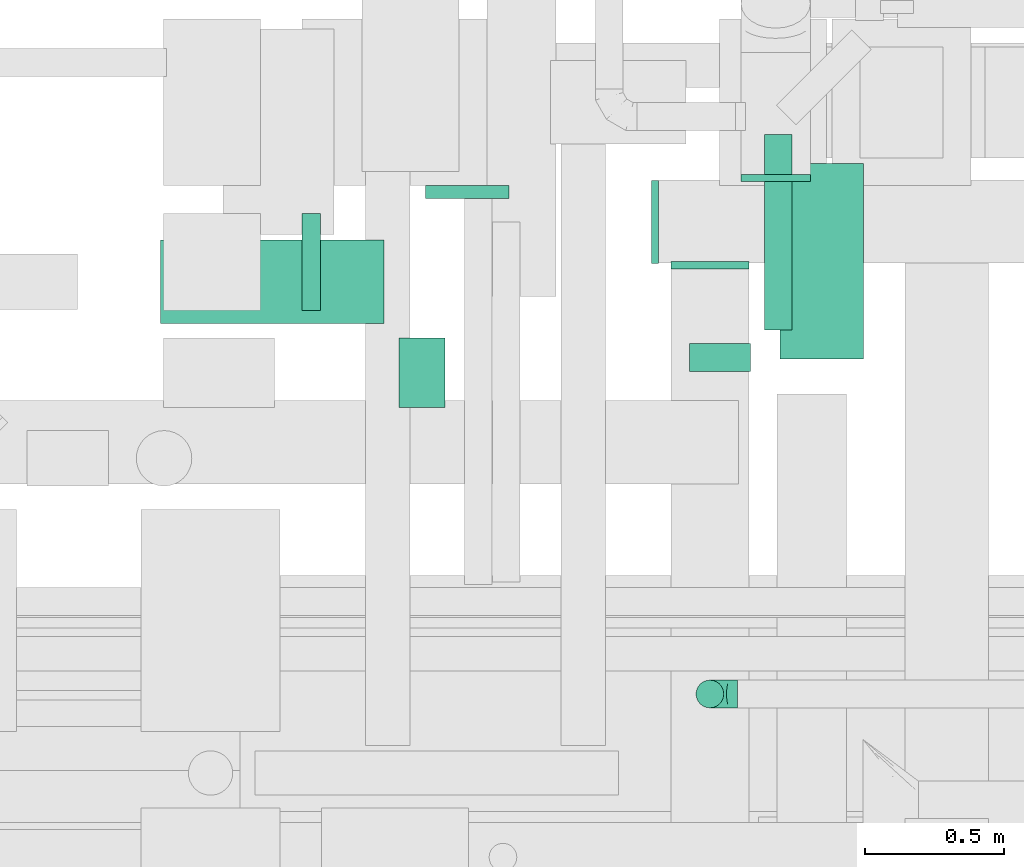
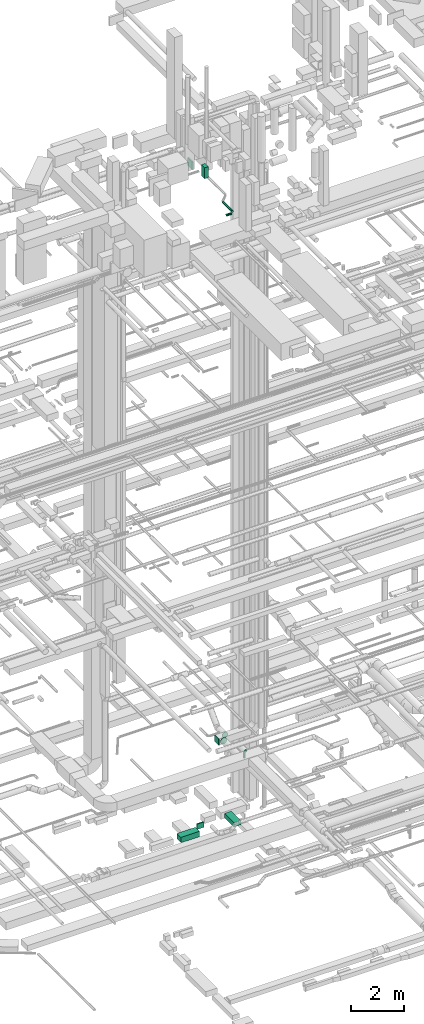
# One storey, part 132 of 337: 8 flow segments, 4 flow fittings.
"""IFC2X3 building model written with IfcOpenShell, lengths in millimetres."""

from ifc_helpers import new_model, entity, si_unit, converted_unit, derived_unit, direction, frame, origin, origin_2d_with_axis, place, context, subcontext, project, spatial, rectangle, circle, extrude, faceted_brep, source, transform, mapped, material, type_object, type_shapes, element, save


model = new_model("IFC2X3")

# Units and contexts
model_context = context("Model", 3, precision=0.01, world=origin(), true_north=direction((6.12303176911189e-17, 1.0)))
body_context = subcontext(model_context, "Body", "Model", "MODEL_VIEW")
ifc_project = project(units=[si_unit("LENGTHUNIT", "METRE", prefix="MILLI"), si_unit("AREAUNIT", "SQUARE_METRE"), si_unit("VOLUMEUNIT", "CUBIC_METRE"), converted_unit("PLANEANGLEUNIT", "DEGREE", entity("IfcRatioMeasure", 0.0174532925199433), si_unit("PLANEANGLEUNIT", "RADIAN"), dimensions=[0, 0, 0, 0, 0, 0, 0]), si_unit("MASSUNIT", "GRAM", prefix="KILO"), derived_unit("MASSDENSITYUNIT", [(si_unit("MASSUNIT", "GRAM", prefix="KILO"), 1), (si_unit("LENGTHUNIT", "METRE"), -3)]), derived_unit("MOMENTOFINERTIAUNIT", [(si_unit("LENGTHUNIT", "METRE"), 4)]), si_unit("TIMEUNIT", "SECOND"), si_unit("FREQUENCYUNIT", "HERTZ"), si_unit("THERMODYNAMICTEMPERATUREUNIT", "DEGREE_CELSIUS"), derived_unit("THERMALTRANSMITTANCEUNIT", [(si_unit("MASSUNIT", "GRAM", prefix="KILO"), 1), (si_unit("THERMODYNAMICTEMPERATUREUNIT", "KELVIN"), -1), (si_unit("TIMEUNIT", "SECOND"), -3)]), derived_unit("VOLUMETRICFLOWRATEUNIT", [(si_unit("LENGTHUNIT", "METRE"), 3), (si_unit("TIMEUNIT", "SECOND"), -1)]), derived_unit("MASSFLOWRATEUNIT", [(si_unit("MASSUNIT", "GRAM", prefix="KILO"), 1), (si_unit("TIMEUNIT", "SECOND"), -1)]), derived_unit("ROTATIONALFREQUENCYUNIT", [(si_unit("TIMEUNIT", "SECOND"), -1)]), si_unit("ELECTRICCURRENTUNIT", "AMPERE"), si_unit("ELECTRICVOLTAGEUNIT", "VOLT"), si_unit("POWERUNIT", "WATT"), si_unit("FORCEUNIT", "NEWTON", prefix="KILO"), si_unit("ILLUMINANCEUNIT", "LUX"), si_unit("LUMINOUSFLUXUNIT", "LUMEN"), si_unit("LUMINOUSINTENSITYUNIT", "CANDELA"), derived_unit("USERDEFINED", [(si_unit("MASSUNIT", "GRAM", prefix="KILO"), -1), (si_unit("LENGTHUNIT", "METRE"), -2), (si_unit("TIMEUNIT", "SECOND"), 3), (si_unit("LUMINOUSFLUXUNIT", "LUMEN"), 1)]), derived_unit("LINEARVELOCITYUNIT", [(si_unit("LENGTHUNIT", "METRE"), 1), (si_unit("TIMEUNIT", "SECOND"), -1)]), si_unit("PRESSUREUNIT", "PASCAL"), derived_unit("USERDEFINED", [(si_unit("LENGTHUNIT", "METRE"), -2), (si_unit("MASSUNIT", "GRAM", prefix="KILO"), 1), (si_unit("TIMEUNIT", "SECOND"), -2)]), derived_unit("LINEARFORCEUNIT", [(si_unit("MASSUNIT", "GRAM", prefix="KILO"), 1), (si_unit("LENGTHUNIT", "METRE"), 1), (si_unit("TIMEUNIT", "SECOND"), -2), (si_unit("LENGTHUNIT", "METRE"), -1)]), derived_unit("PLANARFORCEUNIT", [(si_unit("MASSUNIT", "GRAM", prefix="KILO"), 1), (si_unit("LENGTHUNIT", "METRE"), 1), (si_unit("TIMEUNIT", "SECOND"), -2), (si_unit("LENGTHUNIT", "METRE"), -2)])], contexts=[model_context])

# Site, building, storey
site_placement = place(None, origin())
site = spatial("IfcSite", under=ifc_project, at=site_placement, CompositionType="ELEMENT")
building_placement = place(site_placement, origin())
building = spatial("IfcBuilding", under=site, at=building_placement, CompositionType="ELEMENT")
storey_placement = place(building_placement, origin())
storey = spatial("IfcBuildingStorey", under=building, at=storey_placement, CompositionType="ELEMENT", Elevation=0.0)

# Flow segments
duct_segment_type_1 = type_object("IfcDuctSegmentType", PredefinedType="NOTDEFINED")
flow_segment_1_placement = place(storey_placement, frame((29877.45, 11120.0, -850.0)))
element("IfcFlowSegment", 1, at=flow_segment_1_placement, inside=storey, type_object=duct_segment_type_1, context=body_context, shape_type="SweptSolid", body=[
    extrude(rectangle(XDim=705.060213644064, YDim=300.000000000001, at=origin_2d_with_axis()), frame((150.0, 352.53, 0.0), z_axis=(0.0, 0.0, 1.0), x_axis=(0.0, 1.0, 0.0)), (0.0, 0.0, 1.0), 200.0),
])
flow_segment_2_placement = place(storey_placement, frame((28600.12, 11698.59, -875.0)))
element("IfcFlowSegment", 2, at=flow_segment_2_placement, inside=storey, type_object=duct_segment_type_1, context=body_context, shape_type="SweptSolid", body=[
    extrude(rectangle(XDim=46.4673600000614, YDim=300.000000000001, at=origin_2d_with_axis()), frame((150.0, 23.23, 0.0), z_axis=(0.0, 0.0, 1.0), x_axis=(0.0, -1.0, 0.0)), (0.0, 0.0, 1.0), 250.0),
])
flow_segment_3_placement = place(storey_placement, frame((27644.46, 11248.59, -875.0)))
element("IfcFlowSegment", 3, at=flow_segment_3_placement, inside=storey, type_object=duct_segment_type_1, context=body_context, shape_type="SweptSolid", body=[
    extrude(rectangle(XDim=805.651451250014, YDim=299.999999999999, at=origin_2d_with_axis()), frame((402.83, 150.0, 0.0), z_axis=(0.0, 0.0, 1.0), x_axis=(-1.0, 0.0, 0.0)), (0.0, 0.0, 1.0), 250.0),
])
duct_segment_type_2 = type_object("IfcDuctSegmentType", PredefinedType="NOTDEFINED")
flow_segment_4_placement = place(storey_placement, frame((29818.69, 11224.85, 27348.4)))
element("IfcFlowSegment", 4, at=flow_segment_4_placement, inside=storey, type_object=duct_segment_type_2, context=body_context, shape_type="SweptSolid", body=[
    extrude(circle(Radius=50.0, at=origin_2d_with_axis()), frame((51.6, 0.0, 51.6), z_axis=(0.0, 1.0, 0.0), x_axis=(-1.0, 0.0, 0.0)), (0.0, 0.0, 1.0), 703.57864376269),
])
flow_segment_5_placement = place(storey_placement, frame((29550.28, 11073.25, 27348.4)))
element("IfcFlowSegment", 5, at=flow_segment_5_placement, inside=storey, type_object=duct_segment_type_2, context=body_context, shape_type="SweptSolid", body=[
    extrude(circle(Radius=50.0, at=origin_2d_with_axis()), frame((0.0, 51.6, 51.6), z_axis=(1.0, 0.0, 0.0), x_axis=(0.0, 1.0, 0.0)), (0.0, 0.0, 1.0), 219.999999999985),
])
flow_segment_6_placement = place(storey_placement, frame((29572.65, 9861.05, 3160.0)))
element("IfcFlowSegment", 6, at=flow_segment_6_placement, inside=storey, type_object=duct_segment_type_2, context=body_context, shape_type="SweptSolid", body=[
    extrude(circle(Radius=50.0, at=origin_2d_with_axis()), frame((51.6, 51.6, 0.0), z_axis=(0.0, 0.0, 1.0), x_axis=(0.0, 1.0, 0.0)), (0.0, 0.0, 1.0), 190.000000000053),
])
duct_segment_type_3 = type_object("IfcDuctSegmentType", PredefinedType="NOTDEFINED")
flow_segment_7_placement = place(storey_placement, frame((28504.24, 10945.06, 29550.01)))
element("IfcFlowSegment", 7, at=flow_segment_7_placement, inside=storey, type_object=duct_segment_type_3, context=body_context, shape_type="SweptSolid", body=[
    extrude(rectangle(XDim=165.793664999992, YDim=249.999999999999, at=origin_2d_with_axis()), frame((82.9, 125.0, 0.0), z_axis=(0.0, 0.0, 1.0), x_axis=(-1.0, 0.0, 0.0)), (0.0, 0.0, 1.0), 499.999999999999),
])
flow_segment_8_placement = place(storey_placement, frame((28154.24, 11295.06, 29870.0)))
element("IfcFlowSegment", 8, at=flow_segment_8_placement, inside=storey, type_object=duct_segment_type_3, context=body_context, shape_type="SweptSolid", body=[
    extrude(rectangle(XDim=65.7936149999336, YDim=350.000000000001, at=origin_2d_with_axis()), frame((32.9, 175.0, 0.0)), (0.0, 0.0, 1.0), 349.999999999998),
])

# Flow fittings
ifc_material = material()
duct_fitting_type_1 = type_object("IfcDuctFittingType", PredefinedType="NOTDEFINED", material=ifc_material)
shared_shape_1 = source(origin(), body_context, "Body", "SweptSolid", [
    extrude(rectangle(XDim=24.9999999999999, YDim=300.0, at=origin_2d_with_axis()), frame((12.5, 0.0, -150.0)), (0.0, 0.0, 1.0), 300.0),
])
type_shapes(duct_fitting_type_1, [shared_shape_1])
flow_fitting_1_placement = place(storey_placement, frame((29438.1, 11613.8, 3000.0), z_axis=(0.0, 0.0, 1.0), x_axis=(-1.0, 0.0, 0.0)))
element("IfcFlowFitting", 9, at=flow_fitting_1_placement, inside=storey, type_object=duct_fitting_type_1, material=ifc_material, context=body_context, shape_type="MappedRepresentation", body=[
    mapped(shared_shape_1, transform((0.0, 0.0, 0.0), scale=1.0)),
])
duct_fitting_type_2 = type_object("IfcDuctFittingType", PredefinedType="NOTDEFINED", material=ifc_material)
shared_shape_2 = source(origin(), body_context, "Body", "Brep", [
    faceted_brep([(-100.0, 0.0, -50.0), (-100.0, -12.94, -48.3), (-100.0, -25.0, -43.3), (-100.0, -35.36, -35.36), (-100.0, -43.3, -25.0), (-100.0, -48.3, -12.94), (-100.0, -50.0, 0.0), (-100.0, -48.3, 12.94), (-100.0, -43.3, 25.0), (-100.0, -35.36, 35.36), (-100.0, -25.0, 43.3), (-100.0, -12.94, 48.3), (-100.0, 0.0, 50.0), (-100.0, 12.94, 48.3), (-100.0, 25.0, 43.3), (-100.0, 35.36, 35.36), (-100.0, 43.3, 25.0), (-100.0, 48.3, 12.94), (-100.0, 50.0, 0.0), (-100.0, 48.3, -12.94), (-100.0, 43.3, -25.0), (-100.0, 35.36, -35.36), (-100.0, 25.0, -43.3), (-100.0, 12.94, -48.3), (-76.67, 12.94, 48.3), (-79.9, 25.0, 43.3), (-73.21, 0.0, 50.0), (-82.68, 35.36, 35.36), (-86.15, 48.3, 12.94), (-86.6, 50.0, 0.0), (-84.81, 43.3, 25.0), (-84.81, 43.3, -25.0), (-82.68, 35.36, -35.36), (-86.15, 48.3, -12.94), (-76.67, 12.94, -48.3), (-73.21, 0.0, -50.0), (-79.9, 25.0, -43.3), (-69.74, -12.94, -48.3), (-66.51, -25.0, -43.3), (-63.73, -35.36, -35.36), (-61.6, -43.3, -25.0), (-60.26, -48.3, -12.94), (-59.81, -50.0, 0.0), (-60.26, -48.3, 12.94), (-61.6, -43.3, 25.0), (-63.73, -35.36, 35.36), (-66.51, -25.0, 43.3), (-69.74, -12.94, 48.3), (-36.27, 36.27, 48.3), (-45.1, 45.1, 43.3), (-26.79, 26.79, 50.0), (-52.68, 52.68, 35.36), (-58.49, 58.49, 25.0), (-62.15, 62.15, 12.94), (-63.4, 63.4, 0.0), (-62.15, 62.15, -12.94), (-58.49, 58.49, -25.0), (-52.68, 52.68, -35.36), (-36.27, 36.27, -48.3), (-26.79, 26.79, -50.0), (-45.1, 45.1, -43.3), (-17.32, 17.32, -48.3), (-8.49, 8.49, -43.3), (-0.91, 0.91, -35.36), (4.9, -4.9, -25.0), (8.56, -8.56, -12.94), (9.81, -9.81, 0.0), (8.56, -8.56, 12.94), (4.9, -4.9, 25.0), (-0.91, 0.91, 35.36), (-8.49, 8.49, 43.3), (-17.32, 17.32, 48.3), (-12.94, 76.67, 48.3), (-25.0, 79.9, 43.3), (0.0, 73.21, 50.0), (-35.36, 82.68, 35.36), (-43.3, 84.81, 25.0), (-48.3, 86.15, 12.94), (-50.0, 86.6, 0.0), (-48.3, 86.15, -12.94), (-43.3, 84.81, -25.0), (-35.36, 82.68, -35.36), (-12.94, 76.67, -48.3), (0.0, 73.21, -50.0), (-25.0, 79.9, -43.3), (12.94, 69.74, -48.3), (25.0, 66.51, -43.3), (35.36, 63.73, -35.36), (43.3, 61.6, -25.0), (48.3, 60.26, -12.94), (50.0, 59.81, 0.0), (48.3, 60.26, 12.94), (43.3, 61.6, 25.0), (35.36, 63.73, 35.36), (25.0, 66.51, 43.3), (12.94, 69.74, 48.3), (-12.94, 100.0, -48.3), (-25.0, 100.0, -43.3), (-35.36, 100.0, -35.36), (-43.3, 100.0, -25.0), (-48.3, 100.0, -12.94), (-50.0, 100.0, 0.0), (-48.3, 100.0, 12.94), (-43.3, 100.0, 25.0), (-35.36, 100.0, 35.36), (-25.0, 100.0, 43.3), (-12.94, 100.0, 48.3), (0.0, 100.0, 50.0), (12.94, 100.0, 48.3), (25.0, 100.0, 43.3), (35.36, 100.0, 35.36), (43.3, 100.0, 25.0), (48.3, 100.0, 12.94), (50.0, 100.0, 0.0), (48.3, 100.0, -12.94), (43.3, 100.0, -25.0), (35.36, 100.0, -35.36), (25.0, 100.0, -43.3), (12.94, 100.0, -48.3), (0.0, 100.0, -50.0)], [[[0, 1, 2, 3, 4, 5, 6, 7, 8, 9, 10, 11, 12, 13, 14, 15, 16, 17, 18, 19, 20, 21, 22, 23]], [[24, 25, 14, 13]], [[26, 24, 13, 12]], [[14, 25, 27, 15]], [[28, 29, 18, 17]], [[30, 28, 17, 16]], [[15, 27, 30, 16]], [[20, 31, 32, 21]], [[33, 31, 20, 19]], [[18, 29, 33, 19]], [[34, 35, 0, 23]], [[36, 34, 23, 22]], [[32, 36, 22, 21]], [[2, 1, 37, 38]], [[3, 2, 38, 39]], [[0, 35, 37, 1]], [[5, 4, 40, 41]], [[6, 5, 41, 42]], [[3, 39, 40, 4]], [[6, 42, 43, 7]], [[7, 43, 44, 8]], [[8, 44, 45, 9]], [[10, 46, 47, 11]], [[11, 47, 26, 12]], [[10, 9, 45, 46]], [[48, 49, 25, 24]], [[50, 48, 24, 26]], [[27, 25, 49, 51]], [[52, 53, 28, 30]], [[51, 52, 30, 27]], [[29, 28, 53, 54]], [[55, 56, 31, 33]], [[54, 55, 33, 29]], [[57, 32, 31, 56]], [[58, 59, 35, 34]], [[60, 58, 34, 36]], [[57, 60, 36, 32]], [[37, 35, 59, 61]], [[38, 37, 61, 62]], [[39, 38, 62, 63]], [[41, 40, 64, 65]], [[42, 41, 65, 66]], [[63, 64, 40, 39]], [[43, 42, 66, 67]], [[44, 43, 67, 68]], [[68, 69, 45, 44]], [[46, 45, 69, 70]], [[47, 46, 70, 71]], [[26, 47, 71, 50]], [[72, 73, 49, 48]], [[74, 72, 48, 50]], [[51, 49, 73, 75]], [[76, 77, 53, 52]], [[75, 76, 52, 51]], [[54, 53, 77, 78]], [[79, 80, 56, 55]], [[78, 79, 55, 54]], [[81, 57, 56, 80]], [[82, 83, 59, 58]], [[84, 82, 58, 60]], [[81, 84, 60, 57]], [[61, 59, 83, 85]], [[62, 61, 85, 86]], [[63, 62, 86, 87]], [[65, 64, 88, 89]], [[66, 65, 89, 90]], [[87, 88, 64, 63]], [[67, 66, 90, 91]], [[68, 67, 91, 92]], [[92, 93, 69, 68]], [[70, 69, 93, 94]], [[71, 70, 94, 95]], [[50, 71, 95, 74]], [[96, 97, 98, 99, 100, 101, 102, 103, 104, 105, 106, 107, 108, 109, 110, 111, 112, 113, 114, 115, 116, 117, 118, 119]], [[72, 74, 107, 106]], [[73, 72, 106, 105]], [[75, 73, 105, 104]], [[77, 76, 103, 102]], [[78, 77, 102, 101]], [[75, 104, 103, 76]], [[78, 101, 100, 79]], [[79, 100, 99, 80]], [[80, 99, 98, 81]], [[96, 119, 83, 82]], [[97, 96, 82, 84]], [[84, 81, 98, 97]], [[83, 119, 118, 85]], [[85, 118, 117, 86]], [[86, 117, 116, 87]], [[88, 115, 114, 89]], [[89, 114, 113, 90]], [[87, 116, 115, 88]], [[91, 90, 113, 112]], [[92, 91, 112, 111]], [[93, 92, 111, 110]], [[95, 94, 109, 108]], [[74, 95, 108, 107]], [[110, 109, 94, 93]]]),
])
type_shapes(duct_fitting_type_2, [shared_shape_2])
flow_fitting_2_placement = place(storey_placement, frame((29624.24, 9912.65, 3450.0), z_axis=(0.0, -1.0, 0.0), x_axis=(-1.0, 0.0, 0.0)))
element("IfcFlowFitting", 10, at=flow_fitting_2_placement, inside=storey, type_object=duct_fitting_type_2, material=ifc_material, context=body_context, shape_type="MappedRepresentation", body=[
    mapped(shared_shape_2, transform((0.0, 0.0, 0.0), scale=1.0)),
])
duct_fitting_type_3 = type_object("IfcDuctFittingType", PredefinedType="NOTDEFINED", material=ifc_material)
shared_shape_3 = source(origin(), body_context, "Body", "Brep", [
    faceted_brep([(20.0, 32.35, -120.74), (20.0, 62.5, -108.25), (20.0, 88.39, -88.39), (20.0, 108.25, -62.5), (20.0, 120.74, -32.35), (20.0, 125.0, 0.0), (20.0, 120.74, 32.35), (20.0, 108.25, 62.5), (20.0, 88.39, 88.39), (20.0, 62.5, 108.25), (20.0, 32.35, 120.74), (20.0, 0.0, 125.0), (20.0, -32.35, 120.74), (20.0, -62.5, 108.25), (20.0, -88.39, 88.39), (20.0, -108.25, 62.5), (20.0, -120.74, 32.35), (20.0, -125.0, 0.0), (20.0, -120.74, -32.35), (20.0, -108.25, -62.5), (20.0, -88.39, -88.39), (20.0, -62.5, -108.25), (20.0, -32.35, -120.74), (20.0, 0.0, -125.0), (0.0, 0.0, 125.0), (0.0, 32.35, 120.74), (-6.1, 32.35, 120.74), (-6.1, 0.0, 125.0), (0.0, 62.5, 108.25), (-6.1, 62.5, 108.25), (0.0, 88.39, 88.39), (-6.1, 88.39, 88.39), (0.0, 108.25, 62.5), (0.0, 120.74, 32.35), (-6.1, 120.74, 32.35), (-6.1, 108.25, 62.5), (0.0, 125.0, 0.0), (-6.1, 125.0, 0.0), (0.0, 120.74, -32.35), (-6.1, 120.74, -32.35), (0.0, 108.25, -62.5), (-6.1, 108.25, -62.5), (0.0, 88.39, -88.39), (-6.1, 88.39, -88.39), (0.0, 62.5, -108.25), (0.0, 32.35, -120.74), (-6.1, 32.35, -120.74), (-6.1, 62.5, -108.25), (0.0, 0.0, -125.0), (-6.1, 0.0, -125.0), (0.0, -32.35, -120.74), (-6.1, -32.35, -120.74), (0.0, -62.5, -108.25), (-6.1, -62.5, -108.25), (0.0, -88.39, -88.39), (-6.1, -88.39, -88.39), (0.0, -108.25, -62.5), (0.0, -120.74, -32.35), (-6.1, -120.74, -32.35), (-6.1, -108.25, -62.5), (0.0, -125.0, 0.0), (-6.1, -125.0, 0.0), (0.0, -120.74, 32.35), (-6.1, -120.74, 32.35), (0.0, -108.25, 62.5), (-6.1, -108.25, 62.5), (0.0, -88.39, 88.39), (-6.1, -88.39, 88.39), (0.0, -62.5, 108.25), (0.0, -32.35, 120.74), (-6.1, -32.35, 120.74), (-6.1, -62.5, 108.25)], [[[0, 1, 2, 3, 4, 5, 6, 7, 8, 9, 10, 11, 12, 13, 14, 15, 16, 17, 18, 19, 20, 21, 22, 23]], [[24, 11, 10, 25, 26, 27]], [[25, 10, 9, 28, 29, 26]], [[28, 9, 8, 30, 31, 29]], [[32, 7, 6, 33, 34, 35]], [[33, 6, 5, 36, 37, 34]], [[30, 8, 7, 32, 35, 31]], [[36, 5, 4, 38, 39, 37]], [[38, 4, 3, 40, 41, 39]], [[40, 3, 2, 42, 43, 41]], [[44, 1, 0, 45, 46, 47]], [[45, 0, 23, 48, 49, 46]], [[42, 2, 1, 44, 47, 43]], [[48, 23, 22, 50, 51, 49]], [[50, 22, 21, 52, 53, 51]], [[52, 21, 20, 54, 55, 53]], [[56, 19, 18, 57, 58, 59]], [[57, 18, 17, 60, 61, 58]], [[54, 20, 19, 56, 59, 55]], [[60, 17, 16, 62, 63, 61]], [[62, 16, 15, 64, 65, 63]], [[64, 15, 14, 66, 67, 65]], [[68, 13, 12, 69, 70, 71]], [[69, 12, 11, 24, 27, 70]], [[66, 14, 13, 68, 71, 67]], [[49, 51, 53, 55, 59, 58, 61, 63, 65, 67, 71, 70, 27, 26, 29, 31, 35, 34, 37, 39, 41, 43, 47, 46]]]),
])
type_shapes(duct_fitting_type_3, [shared_shape_3])
flow_fitting_3_placement = place(storey_placement, frame((29861.25, 11764.96, 3000.0), z_axis=(0.0, 0.0, -1.0), x_axis=(0.0, 1.0, 0.0)))
element("IfcFlowFitting", 11, at=flow_fitting_3_placement, inside=storey, type_object=duct_fitting_type_3, material=ifc_material, context=body_context, shape_type="MappedRepresentation", body=[
    mapped(shared_shape_3, transform((0.0, 0.0, 0.0), scale=1.0)),
])
duct_fitting_type_4 = type_object("IfcDuctFittingType", PredefinedType="NOTDEFINED", material=ifc_material)
shared_shape_4 = source(origin(), body_context, "Body", "Brep", [
    faceted_brep([(20.0, 0.0, -140.0), (20.0, 36.23, -135.23), (20.0, 70.0, -121.24), (20.0, 98.99, -98.99), (20.0, 121.24, -70.0), (20.0, 135.23, -36.23), (20.0, 140.0, 0.0), (20.0, 135.23, 36.23), (20.0, 121.24, 70.0), (20.0, 98.99, 98.99), (20.0, 70.0, 121.24), (20.0, 36.23, 135.23), (20.0, 0.0, 140.0), (20.0, -36.23, 135.23), (20.0, -70.0, 121.24), (20.0, -98.99, 98.99), (20.0, -121.24, 70.0), (20.0, -135.23, 36.23), (20.0, -140.0, 0.0), (20.0, -135.23, -36.23), (20.0, -121.24, -70.0), (20.0, -98.99, -98.99), (20.0, -70.0, -121.24), (20.0, -36.23, -135.23), (0.0, 0.0, 140.0), (-6.1, 0.0, 140.0), (-6.1, -36.23, 135.23), (0.0, -36.23, 135.23), (-6.1, -70.0, 121.24), (0.0, -70.0, 121.24), (0.0, -98.99, 98.99), (-6.1, -98.99, 98.99), (0.0, -121.24, 70.0), (-6.1, -121.24, 70.0), (-6.1, -135.23, 36.23), (0.0, -135.23, 36.23), (-6.1, -140.0, 0.0), (0.0, -140.0, 0.0), (-6.1, -135.23, -36.23), (0.0, -135.23, -36.23), (-6.1, -121.24, -70.0), (0.0, -121.24, -70.0), (0.0, -98.99, -98.99), (-6.1, -98.99, -98.99), (0.0, -70.0, -121.24), (-6.1, -70.0, -121.24), (-6.1, -36.23, -135.23), (0.0, -36.23, -135.23), (-6.1, 0.0, -140.0), (0.0, 0.0, -140.0), (-6.1, 36.23, -135.23), (0.0, 36.23, -135.23), (-6.1, 70.0, -121.24), (0.0, 70.0, -121.24), (0.0, 98.99, -98.99), (-6.1, 98.99, -98.99), (0.0, 121.24, -70.0), (-6.1, 121.24, -70.0), (-6.1, 135.23, -36.23), (0.0, 135.23, -36.23), (-6.1, 140.0, 0.0), (0.0, 140.0, 0.0), (-6.1, 135.23, 36.23), (0.0, 135.23, 36.23), (-6.1, 121.24, 70.0), (0.0, 121.24, 70.0), (0.0, 98.99, 98.99), (-6.1, 98.99, 98.99), (0.0, 70.0, 121.24), (-6.1, 70.0, 121.24), (-6.1, 36.23, 135.23), (0.0, 36.23, 135.23)], [[[0, 1, 2, 3, 4, 5, 6, 7, 8, 9, 10, 11, 12, 13, 14, 15, 16, 17, 18, 19, 20, 21, 22, 23]], [[13, 12, 24, 25, 26, 27]], [[14, 13, 27, 26, 28, 29]], [[30, 15, 14, 29, 28, 31]], [[17, 16, 32, 33, 34, 35]], [[18, 17, 35, 34, 36, 37]], [[32, 16, 15, 30, 31, 33]], [[19, 18, 37, 36, 38, 39]], [[20, 19, 39, 38, 40, 41]], [[42, 21, 20, 41, 40, 43]], [[23, 22, 44, 45, 46, 47]], [[0, 23, 47, 46, 48, 49]], [[44, 22, 21, 42, 43, 45]], [[1, 0, 49, 48, 50, 51]], [[2, 1, 51, 50, 52, 53]], [[54, 3, 2, 53, 52, 55]], [[5, 4, 56, 57, 58, 59]], [[6, 5, 59, 58, 60, 61]], [[56, 4, 3, 54, 55, 57]], [[7, 6, 61, 60, 62, 63]], [[8, 7, 63, 62, 64, 65]], [[66, 9, 8, 65, 64, 67]], [[11, 10, 68, 69, 70, 71]], [[12, 11, 71, 70, 25, 24]], [[68, 10, 9, 66, 67, 69]], [[46, 45, 43, 40, 38, 36, 34, 33, 31, 28, 26, 25, 70, 69, 67, 64, 62, 60, 58, 57, 55, 52, 50, 48]]]),
])
type_shapes(duct_fitting_type_4, [shared_shape_4])
flow_fitting_4_placement = place(storey_placement, frame((29624.24, 11464.96, 3000.0), z_axis=(0.0, 0.0, -1.0), x_axis=(0.0, -1.0, 0.0)))
element("IfcFlowFitting", 12, at=flow_fitting_4_placement, inside=storey, type_object=duct_fitting_type_4, material=ifc_material, context=body_context, shape_type="MappedRepresentation", body=[
    mapped(shared_shape_4, transform((0.0, 0.0, 0.0), scale=1.0)),
])

save(model, "model.ifc")
